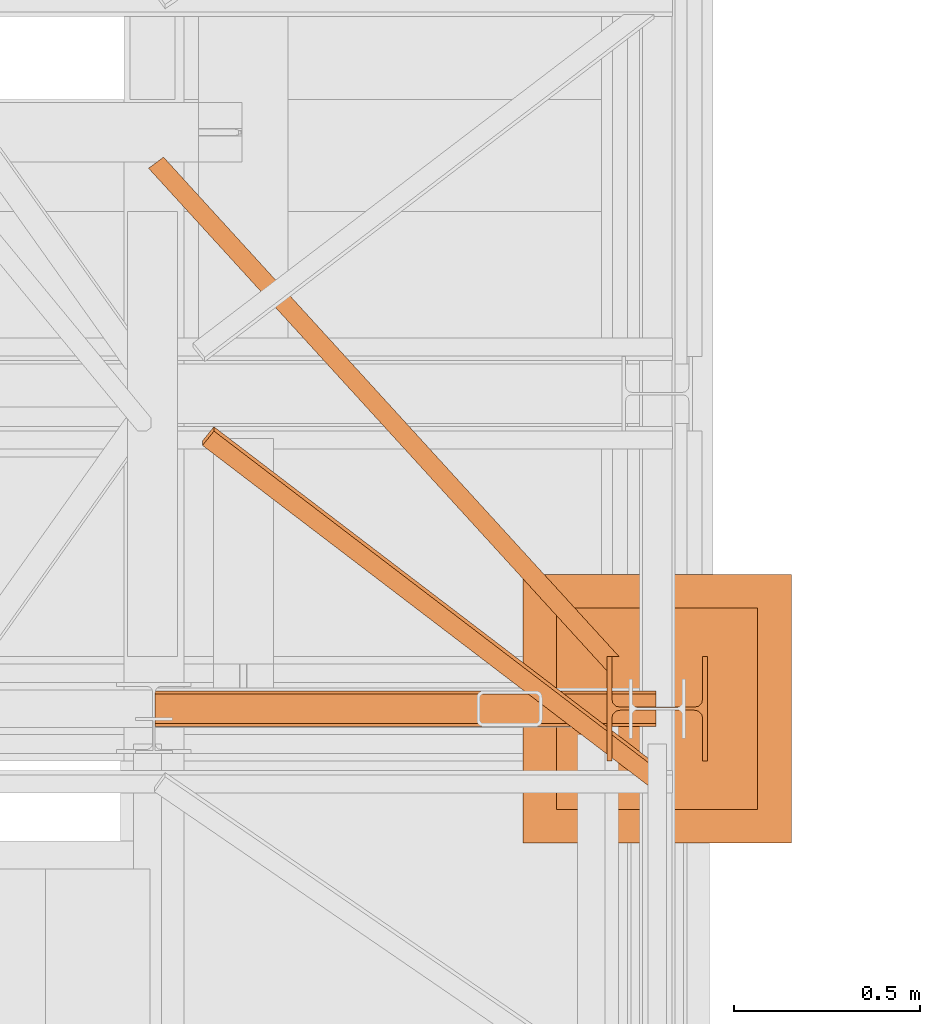
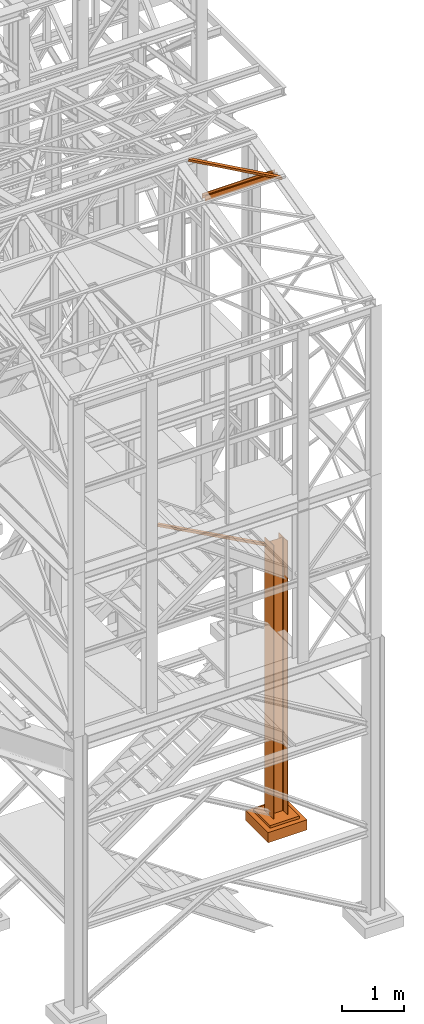
# One storey, part 60 of 208: 5 proxies.
"""IFC2X3 building model written with IfcOpenShell, lengths in millimetres."""

from ifc_helpers import new_model, entity, si_unit, converted_unit, frame, origin, origin_with_axes, place, context, subcontext, project, spatial, faceted_brep, element, save


model = new_model("IFC2X3")

# Units and contexts
model_context = context("Model", 3, precision=1e-05, world=origin())
plan_context = context("Plan", 3, precision=1e-05, world=origin())
body_context = subcontext(model_context, "Body", "Model", "MODEL_VIEW")
ifc_project = project(units=[si_unit("LENGTHUNIT", "METRE", prefix="MILLI"), converted_unit("PLANEANGLEUNIT", "DEGREE", entity("IfcPlaneAngleMeasure", 0.0174532925199433), si_unit("PLANEANGLEUNIT", "RADIAN"), dimensions=[0, 0, 0, 0, 0, 0, 0]), si_unit("AREAUNIT", "SQUARE_METRE"), si_unit("VOLUMEUNIT", "CUBIC_METRE")], contexts=[model_context, plan_context])

# Building, storey
building_placement = place(None, origin())
building = spatial("IfcBuilding", under=ifc_project, at=building_placement, CompositionType="COMPLEX")
storey_placement = place(building_placement, origin_with_axes())
storey = spatial("IfcBuildingStorey", under=building, at=storey_placement, Name="Geschoss", CompositionType="ELEMENT")

# Proxies
proxy_1_placement = place(storey_placement, frame((6563.25496316425, -22202.57439091393, -65.01000000000022), z_axis=(0.0, 0.0, 1.0), x_axis=(1.0, 0.0, 0.0)))
element("IfcBuildingElementProxy", 1, at=proxy_1_placement, inside=storey, context=body_context, shape_type="Brep", body=[
    faceted_brep([(0.009999999999308784, 0.00999999999839929, 5350.00999463558), (0.009999999999308784, 280.0100011920913, 5350.010005364416), (13.00999654292991, 280.0100011920913, 5350.010005364416), (13.00999654292991, 168.0100014603122, 5350.010005364416), (15.49606157302787, 155.588920617698, 5350.010005364416), (24.58892149686744, 146.49606488481, 5350.010005364416), (37.01000047683647, 144.0100007860347, 5350.010005364416), (233.0100102519973, 144.0100007860347, 5350.010005364416), (245.4310892319663, 146.49606488481, 5350.010005364416), (254.5239491558059, 155.588920617698, 5350.010005364416), (257.0100141859039, 168.0100014603122, 5350.010005364416), (257.0100141859039, 280.0100011920913, 5350.010005364416), (270.0100107288345, 280.0100011920913, 5350.010005364416), (270.0100107288345, 0.00999999999839929, 5350.00999463558), (257.0100141859039, 0.00999999999839929, 5350.00999463558), (257.0100141859039, 112.0099997317775, 5350.00999463558), (254.5239491558059, 124.4310805743917, 5350.00999463558), (245.4310892319663, 133.5239363072797, 5350.00999463558), (233.0100102519973, 136.010000406055, 5350.00999463558), (37.01000047683647, 136.010000406055, 5350.00999463558), (24.58892149686744, 133.5239363072797, 5350.00999463558), (15.49606157302787, 124.4310805743917, 5350.00999463558), (13.00999654292991, 112.0099997317775, 5350.00999463558), (13.00999654292991, 0.00999999999839929, 5350.00999463558), (0.009999999999308784, 280.0100011920913, 5350.010005364416), (0.009999999999308784, 0.00999999999839929, 5350.00999463558), (0.009999999999308784, 0.00999999999839929, 0.01000000000021828), (0.009999999999308784, 280.0100011920913, 0.01000000000021828), (0.009999999999308784, 280.0100011920913, 5350.010005364416), (0.009999999999308784, 280.0100011920913, 0.01000000000021828), (13.00999654292991, 280.0100011920913, 0.01000000000021828), (13.00999654292991, 280.0100011920913, 5350.010005364416), (13.00999654292991, 280.0100011920913, 5350.010005364416), (13.00999654292991, 280.0100011920913, 0.01000000000021828), (13.00999654292991, 168.0100014603122, 0.01000000000021828), (13.00999654292991, 168.0100014603122, 5350.010005364416), (13.00999654292991, 168.0100014603122, 5350.010005364416), (13.00999654292991, 168.0100014603122, 0.01000000000021828), (15.49606157302787, 155.588920617698, 0.01000000000021828), (15.49606157302787, 155.588920617698, 5350.010005364416), (15.49606157302787, 155.588920617698, 5350.010005364416), (15.49606157302787, 155.588920617698, 0.01000000000021828), (24.58892149686744, 146.49606488481, 0.01000000000021828), (24.58892149686744, 146.49606488481, 5350.010005364416), (24.58892149686744, 146.49606488481, 5350.010005364416), (24.58892149686744, 146.49606488481, 0.01000000000021828), (37.01000047683647, 144.0100007860347, 0.01000000000021828), (37.01000047683647, 144.0100007860347, 5350.010005364416), (37.01000047683647, 144.0100007860347, 5350.010005364416), (37.01000047683647, 144.0100007860347, 0.01000000000021828), (233.0100102519973, 144.0100007860347, 0.01000000000021828), (233.0100102519973, 144.0100007860347, 5350.010005364416), (233.0100102519973, 144.0100007860347, 5350.010005364416), (233.0100102519973, 144.0100007860347, 0.01000000000021828), (245.4310892319663, 146.49606488481, 0.01000000000021828), (245.4310892319663, 146.49606488481, 5350.010005364416), (245.4310892319663, 146.49606488481, 5350.010005364416), (245.4310892319663, 146.49606488481, 0.01000000000021828), (254.5239491558059, 155.588920617698, 0.01000000000021828), (254.5239491558059, 155.588920617698, 5350.010005364416), (254.5239491558059, 155.588920617698, 5350.010005364416), (254.5239491558059, 155.588920617698, 0.01000000000021828), (257.0100141859039, 168.0100014603122, 0.01000000000021828), (257.0100141859039, 168.0100014603122, 5350.010005364416), (257.0100141859039, 168.0100014603122, 5350.010005364416), (257.0100141859039, 168.0100014603122, 0.01000000000021828), (257.0100141859039, 280.0100011920913, 0.01000000000021828), (257.0100141859039, 280.0100011920913, 5350.010005364416), (257.0100141859039, 280.0100011920913, 5350.010005364416), (257.0100141859039, 280.0100011920913, 0.01000000000021828), (270.0100107288345, 280.0100011920913, 0.01000000000021828), (270.0100107288345, 280.0100011920913, 5350.010005364416), (270.0100107288345, 0.00999999999839929, 5350.00999463558), (270.0100107288345, 280.0100011920913, 5350.010005364416), (270.0100107288345, 280.0100011920913, 0.01000000000021828), (270.0100107288345, 0.00999999999839929, 0.01000000000021828), (257.0100141859039, 0.00999999999839929, 5350.00999463558), (270.0100107288345, 0.00999999999839929, 5350.00999463558), (270.0100107288345, 0.00999999999839929, 0.01000000000021828), (257.0100141859039, 0.00999999999839929, 0.01000000000021828), (257.0100141859039, 112.0099997317775, 5350.00999463558), (257.0100141859039, 0.00999999999839929, 5350.00999463558), (257.0100141859039, 0.00999999999839929, 0.01000000000021828), (257.0100141859039, 112.0099997317775, 0.01000000000021828), (254.5239491558059, 124.4310805743917, 5350.00999463558), (257.0100141859039, 112.0099997317775, 5350.00999463558), (257.0100141859039, 112.0099997317775, 0.01000000000021828), (254.5239491558059, 124.4310805743917, 0.01000000000021828), (245.4310892319663, 133.5239363072797, 5350.00999463558), (254.5239491558059, 124.4310805743917, 5350.00999463558), (254.5239491558059, 124.4310805743917, 0.01000000000021828), (245.4310892319663, 133.5239363072797, 0.01000000000021828), (233.0100102519973, 136.010000406055, 5350.00999463558), (245.4310892319663, 133.5239363072797, 5350.00999463558), (245.4310892319663, 133.5239363072797, 0.01000000000021828), (233.0100102519973, 136.010000406055, 0.01000000000021828), (37.01000047683647, 136.010000406055, 5350.00999463558), (233.0100102519973, 136.010000406055, 5350.00999463558), (233.0100102519973, 136.010000406055, 0.01000000000021828), (37.01000047683647, 136.010000406055, 0.01000000000021828), (24.58892149686744, 133.5239363072797, 5350.00999463558), (37.01000047683647, 136.010000406055, 5350.00999463558), (37.01000047683647, 136.010000406055, 0.01000000000021828), (24.58892149686744, 133.5239363072797, 0.01000000000021828), (15.49606157302787, 124.4310805743917, 5350.00999463558), (24.58892149686744, 133.5239363072797, 5350.00999463558), (24.58892149686744, 133.5239363072797, 0.01000000000021828), (15.49606157302787, 124.4310805743917, 0.01000000000021828), (13.00999654292991, 112.0099997317775, 5350.00999463558), (15.49606157302787, 124.4310805743917, 5350.00999463558), (15.49606157302787, 124.4310805743917, 0.01000000000021828), (13.00999654292991, 112.0099997317775, 0.01000000000021828), (13.00999654292991, 0.00999999999839929, 5350.00999463558), (13.00999654292991, 112.0099997317775, 5350.00999463558), (13.00999654292991, 112.0099997317775, 0.01000000000021828), (13.00999654292991, 0.00999999999839929, 0.01000000000021828), (0.009999999999308784, 0.00999999999839929, 5350.00999463558), (13.00999654292991, 0.00999999999839929, 5350.00999463558), (13.00999654292991, 0.00999999999839929, 0.01000000000021828), (0.009999999999308784, 0.00999999999839929, 0.01000000000021828), (0.009999999999308784, 0.00999999999839929, 0.01000000000021828), (13.00999654292991, 0.00999999999839929, 0.01000000000021828), (13.00999654292991, 112.0099997317775, 0.01000000000021828), (15.49606157302787, 124.4310805743917, 0.01000000000021828), (24.58892149686744, 133.5239363072797, 0.01000000000021828), (37.01000047683647, 136.010000406055, 0.01000000000021828), (233.0100102519973, 136.010000406055, 0.01000000000021828), (245.4310892319663, 133.5239363072797, 0.01000000000021828), (254.5239491558059, 124.4310805743917, 0.01000000000021828), (257.0100141859039, 112.0099997317775, 0.01000000000021828), (257.0100141859039, 0.00999999999839929, 0.01000000000021828), (270.0100107288345, 0.00999999999839929, 0.01000000000021828), (270.0100107288345, 280.0100011920913, 0.01000000000021828), (257.0100141859039, 280.0100011920913, 0.01000000000021828), (257.0100141859039, 168.0100014603122, 0.01000000000021828), (254.5239491558059, 155.588920617698, 0.01000000000021828), (245.4310892319663, 146.49606488481, 0.01000000000021828), (233.0100102519973, 144.0100007860347, 0.01000000000021828), (37.01000047683647, 144.0100007860347, 0.01000000000021828), (24.58892149686744, 146.49606488481, 0.01000000000021828), (15.49606157302787, 155.588920617698, 0.01000000000021828), (13.00999654292991, 168.0100014603122, 0.01000000000021828), (13.00999654292991, 280.0100011920913, 0.01000000000021828), (0.009999999999308784, 280.0100011920913, 0.01000000000021828)], [[[0, 1, 2, 3, 4, 5, 6, 7, 8, 9, 10, 11, 12, 13, 14, 15, 16, 17, 18, 19, 20, 21, 22, 23]], [[24, 25, 26, 27]], [[28, 29, 30, 31]], [[32, 33, 34, 35]], [[36, 37, 38, 39]], [[40, 41, 42, 43]], [[44, 45, 46, 47]], [[48, 49, 50, 51]], [[52, 53, 54, 55]], [[56, 57, 58, 59]], [[60, 61, 62, 63]], [[64, 65, 66, 67]], [[68, 69, 70, 71]], [[72, 73, 74, 75]], [[76, 77, 78, 79]], [[80, 81, 82, 83]], [[84, 85, 86, 87]], [[88, 89, 90, 91]], [[92, 93, 94, 95]], [[96, 97, 98, 99]], [[100, 101, 102, 103]], [[104, 105, 106, 107]], [[108, 109, 110, 111]], [[112, 113, 114, 115]], [[116, 117, 118, 119]], [[120, 121, 122, 123, 124, 125, 126, 127, 128, 129, 130, 131, 132, 133, 134, 135, 136, 137, 138, 139, 140, 141, 142, 143]]], orient=[[False], [False], [False], [False], [False], [False], [False], [False], [False], [False], [False], [False], [False], [False], [False], [False], [False], [False], [False], [False], [False], [False], [False], [False], [False], [False]]),
])
proxy_2_placement = place(storey_placement, frame((6337.754970998533, -22422.57439031789, -315.01), z_axis=(0.0, 0.0, 1.0), x_axis=(1.0, 0.0, 0.0)))
element("IfcBuildingElementProxy", 2, at=proxy_2_placement, inside=storey, context=body_context, shape_type="Brep", body=[
    faceted_brep([(630.0100000000002, 630.0099999999984, 250.01), (630.0100000000002, 90.0099999999984, 250.01), (90.01000000000022, 90.0099999999984, 250.01), (90.01000000000022, 630.0099999999984, 250.01), (630.0100000000002, 630.0099999999984, 200.01), (630.0100000000002, 90.0099999999984, 200.01), (630.0100000000002, 90.0099999999984, 250.01), (630.0100000000002, 630.0099999999984, 250.01), (90.01000000000022, 630.0099999999984, 200.01), (630.0100000000002, 630.0099999999984, 200.01), (630.0100000000002, 630.0099999999984, 250.01), (90.01000000000022, 630.0099999999984, 250.01), (90.01000000000022, 90.0099999999984, 200.01), (90.01000000000022, 630.0099999999984, 200.01), (90.01000000000022, 630.0099999999984, 250.01), (90.01000000000022, 90.0099999999984, 250.01), (630.0100000000002, 90.0099999999984, 200.01), (90.01000000000022, 90.0099999999984, 200.01), (90.01000000000022, 90.0099999999984, 250.01), (630.0100000000002, 90.0099999999984, 250.01), (720.0100000000002, 0.00999999999839929, 0.009999999999990905), (720.0100000000002, 720.0099999999984, 0.009999999999990905), (0.01000000000021828, 720.0099999999984, 0.009999999999990905), (0.01000000000021828, 0.00999999999839929, 0.009999999999990905), (720.0100000000002, 720.0099999999984, 200.01), (720.0100000000002, 0.00999999999839929, 200.01), (0.01000000000021828, 0.00999999999839929, 200.01), (0.01000000000021828, 720.0099999999984, 200.01), (90.01000000000022, 90.0099999999984, 200.01), (630.0100000000002, 90.0099999999984, 200.01), (630.0100000000002, 630.0099999999984, 200.01), (90.01000000000022, 630.0099999999984, 200.01), (720.0100000000002, 720.0099999999984, 0.009999999999990905), (720.0100000000002, 0.00999999999839929, 0.009999999999990905), (720.0100000000002, 0.00999999999839929, 200.01), (720.0100000000002, 720.0099999999984, 200.01), (0.01000000000021828, 720.0099999999984, 0.009999999999990905), (720.0100000000002, 720.0099999999984, 0.009999999999990905), (720.0100000000002, 720.0099999999984, 200.01), (0.01000000000021828, 720.0099999999984, 200.01), (0.01000000000021828, 0.00999999999839929, 0.009999999999990905), (0.01000000000021828, 720.0099999999984, 0.009999999999990905), (0.01000000000021828, 720.0099999999984, 200.01), (0.01000000000021828, 0.00999999999839929, 200.01), (720.0100000000002, 0.00999999999839929, 0.009999999999990905), (0.01000000000021828, 0.00999999999839929, 0.009999999999990905), (0.01000000000021828, 0.00999999999839929, 200.01), (720.0100000000002, 0.00999999999839929, 200.01)], [[[0, 1, 2, 3]], [[4, 5, 6, 7]], [[8, 9, 10, 11]], [[12, 13, 14, 15]], [[16, 17, 18, 19]], [[20, 21, 22, 23]], [[24, 25, 26, 27], [28, 29, 30, 31]], [[32, 33, 34, 35]], [[36, 37, 38, 39]], [[40, 41, 42, 43]], [[44, 45, 46, 47]]], orient=[[False], [False], [False], [False], [False], [False], [False, False], [False], [False], [False], [False]]),
])
proxy_3_placement = place(storey_placement, frame((5333.759663873269, -21961.05414175754, 5124.989999999998), z_axis=(0.0, 0.0, 1.0), x_axis=(1.0, 0.0, 0.0)))
element("IfcBuildingElementProxy", 3, at=proxy_3_placement, inside=storey, context=body_context, shape_type="Brep", body=[
    faceted_brep([(40.1206636007646, 1377.774890675592, 50.01000000000022), (40.1206636007646, 1377.774890675592, 0.01000000000021828), (1261.7460710356, 38.48975203570444, 0.01000000000021828), (1261.746071035599, 38.48975203570444, 50.01000000000022), (40.1206636007646, 1377.774890675592, 0.01000000000021828), (0.01000000000021828, 1347.923011915511, 0.01000000000021828), (1229.50529929098, 0.00999999999839929, 0.01000000000021828), (1229.50529929098, 38.48975203570444, 0.01000000000021828), (1261.7460710356, 38.48975203570444, 0.01000000000021828), (0.01000000000021828, 1347.923011915511, 0.01000000000021828), (0.01000000000021828, 1347.923011915511, 50.01000000000022), (1229.505299290981, 0.00999999999839929, 50.01000000000022), (1229.50529929098, 0.00999999999839929, 0.01000000000021828), (0.01000000000021828, 1347.923011915511, 50.01000000000022), (40.1206636007646, 1377.774890675592, 50.01000000000022), (1261.746071035599, 38.48975203570444, 50.01000000000022), (1229.50529929098, 38.48975203570444, 50.01000000000022), (1229.505299290981, 0.00999999999839929, 50.01000000000022), (40.1206636007646, 1377.774890675592, 50.01000000000022), (0.01000000000021828, 1347.923011915511, 50.01000000000022), (0.01000000000021828, 1347.923011915511, 0.01000000000021828), (40.1206636007646, 1377.774890675592, 0.01000000000021828), (36.9118105127036, 1375.386740374783, 4.010000000000218), (3.218853088061223, 1350.31116221632, 4.010000000000218), (3.218853088061223, 1350.31116221632, 46.01000000000022), (36.9118105127036, 1375.386740374783, 46.01000000000022), (36.9118105127036, 1375.386740374783, 46.01000000000022), (1256.358872948355, 38.48975203570444, 46.01000000000022), (1256.358872948355, 38.48975203570444, 4.010000000000218), (36.9118105127036, 1375.386740374783, 4.010000000000218), (36.9118105127036, 1375.386740374783, 4.010000000000218), (1256.358872948355, 38.48975203570444, 4.010000000000218), (1229.50529929098, 38.48975203570444, 4.010000000000218), (1229.50529929098, 5.916061132360483, 4.010000000000218), (3.218853088061223, 1350.31116221632, 4.010000000000218), (3.218853088061223, 1350.31116221632, 4.010000000000218), (1229.50529929098, 5.916061132360483, 4.010000000000218), (1229.50529929098, 5.916061132360483, 46.01000000000022), (3.218853088061223, 1350.31116221632, 46.01000000000022), (3.218853088061223, 1350.31116221632, 46.01000000000022), (1229.50529929098, 5.916061132360483, 46.01000000000022), (1229.50529929098, 38.48975203570444, 46.01000000000022), (1256.358872948355, 38.48975203570444, 46.01000000000022), (36.9118105127036, 1375.386740374783, 46.01000000000022), (1229.50529929098, 38.48975203570444, 50.01000000000022), (1261.746071035599, 38.48975203570444, 50.01000000000022), (1261.7460710356, 38.48975203570444, 0.01000000000021828), (1229.50529929098, 38.48975203570444, 0.01000000000021828), (1229.50529929098, 38.48975203570444, 4.010000000000218), (1256.358872948355, 38.48975203570444, 4.010000000000218), (1256.358872948355, 38.48975203570444, 46.01000000000022), (1229.50529929098, 38.48975203570444, 46.01000000000022), (1229.50529929098, 38.48975203570444, 0.01000000000021828), (1229.50529929098, 0.00999999999839929, 0.01000000000021828), (1229.505299290981, 0.00999999999839929, 50.01000000000022), (1229.50529929098, 38.48975203570444, 50.01000000000022), (1229.50529929098, 38.48975203570444, 46.01000000000022), (1229.50529929098, 5.916061132360483, 46.01000000000022), (1229.50529929098, 5.916061132360483, 4.010000000000218), (1229.50529929098, 38.48975203570444, 4.010000000000218)], [[[0, 1, 2, 3]], [[4, 5, 6, 7, 8]], [[9, 10, 11, 12]], [[13, 14, 15, 16, 17]], [[18, 19, 20, 21], [22, 23, 24, 25]], [[26, 27, 28, 29]], [[30, 31, 32, 33, 34]], [[35, 36, 37, 38]], [[39, 40, 41, 42, 43]], [[44, 45, 46, 47, 48, 49, 50, 51]], [[52, 53, 54, 55, 56, 57, 58, 59]]], orient=[[False], [False], [False], [False], [False, False], [False], [False], [False], [False], [False], [False]]),
])
proxy_4_placement = place(storey_placement, frame((5351.254972280036, -22111.04177386488, 12392.75857612322), z_axis=(0.0, 0.0, 1.0), x_axis=(1.0, 0.0, 0.0)))
element("IfcBuildingElementProxy", 4, at=proxy_4_placement, inside=storey, context=body_context, shape_type="Brep", body=[
    faceted_brep([(1344.009999947846, 8.010000000002037, 0.01000000000021828), (1344.009999947846, 0.01000000000203727, 0.01000000000021828), (1344.009999947846, 0.01000000000203727, 100.0100000000002), (1344.009999947846, 8.010000000002037, 100.0100000000002), (1344.009999947846, 8.010000000002037, 52.51000000000022), (1344.009999947846, 88.01000000000204, 52.51000000000022), (1344.009999947846, 88.01000000000204, 100.0100000000002), (1344.009999947846, 96.01000000000204, 100.0100000000002), (1344.009999947846, 96.01000000000204, 0.01000000000021828), (1344.009999947846, 88.01000000000204, 0.01000000000021828), (1344.009999947846, 88.01000000000204, 47.51000000000022), (1344.009999947846, 8.010000000002037, 47.51000000000022), (1344.009999947846, 0.01000000000203727, 0.01000000000021828), (1344.009999947846, 8.010000000002037, 0.01000000000021828), (0.01000000000021828, 8.010000000005675, 0.01000000000021828), (0.01000000000021828, 0.01000000000567525, 0.01000000000021828), (1344.009999947846, 0.01000000000203727, 100.0100000000002), (1344.009999947846, 0.01000000000203727, 0.01000000000021828), (0.01000000000021828, 0.01000000000567525, 0.01000000000021828), (0.01000000000021828, 0.01000000000567525, 100.0100000000002), (1344.009999947846, 8.010000000002037, 100.0100000000002), (1344.009999947846, 0.01000000000203727, 100.0100000000002), (0.01000000000021828, 0.01000000000567525, 100.0100000000002), (0.01000000000021828, 8.010000000005675, 100.0100000000002), (1344.009999947846, 8.010000000002037, 52.51000000000022), (1344.009999947846, 8.010000000002037, 100.0100000000002), (0.01000000000021828, 8.010000000005675, 100.0100000000002), (0.01000000000021828, 8.010000000005675, 52.51000000000022), (1344.009999947846, 88.01000000000204, 52.51000000000022), (1344.009999947846, 8.010000000002037, 52.51000000000022), (0.01000000000021828, 8.010000000005675, 52.51000000000022), (0.01000000000021828, 88.01000000000568, 52.51000000000022), (1344.009999947846, 88.01000000000204, 100.0100000000002), (1344.009999947846, 88.01000000000204, 52.51000000000022), (0.01000000000021828, 88.01000000000568, 52.51000000000022), (0.01000000000021828, 88.01000000000568, 100.0100000000002), (1344.009999947846, 96.01000000000204, 100.0100000000002), (1344.009999947846, 88.01000000000204, 100.0100000000002), (0.01000000000021828, 88.01000000000568, 100.0100000000002), (0.01000000000021828, 96.01000000000568, 100.0100000000002), (1344.009999947846, 96.01000000000204, 0.01000000000021828), (1344.009999947846, 96.01000000000204, 100.0100000000002), (0.01000000000021828, 96.01000000000568, 100.0100000000002), (0.01000000000021828, 96.01000000000568, 0.01000000000021828), (1344.009999947846, 88.01000000000204, 0.01000000000021828), (1344.009999947846, 96.01000000000204, 0.01000000000021828), (0.01000000000021828, 96.01000000000568, 0.01000000000021828), (0.01000000000021828, 88.01000000000568, 0.01000000000021828), (1344.009999947846, 88.01000000000204, 47.51000000000022), (1344.009999947846, 88.01000000000204, 0.01000000000021828), (0.01000000000021828, 88.01000000000568, 0.01000000000021828), (0.01000000000021828, 88.01000000000568, 47.51000000000022), (1344.009999947846, 8.010000000002037, 47.51000000000022), (1344.009999947846, 88.01000000000204, 47.51000000000022), (0.01000000000021828, 88.01000000000568, 47.51000000000022), (0.01000000000021828, 8.010000000005675, 47.51000000000022), (1344.009999947846, 8.010000000002037, 0.01000000000021828), (1344.009999947846, 8.010000000002037, 47.51000000000022), (0.01000000000021828, 8.010000000005675, 47.51000000000022), (0.01000000000021828, 8.010000000005675, 0.01000000000021828), (0.01000000000021828, 8.010000000005675, 0.01000000000021828), (0.01000000000021828, 8.010000000005675, 47.51000000000022), (0.01000000000021828, 88.01000000000568, 47.51000000000022), (0.01000000000021828, 88.01000000000568, 0.01000000000021828), (0.01000000000021828, 96.01000000000568, 0.01000000000021828), (0.01000000000021828, 96.01000000000568, 100.0100000000002), (0.01000000000021828, 88.01000000000568, 100.0100000000002), (0.01000000000021828, 88.01000000000568, 52.51000000000022), (0.01000000000021828, 8.010000000005675, 52.51000000000022), (0.01000000000021828, 8.010000000005675, 100.0100000000002), (0.01000000000021828, 0.01000000000567525, 100.0100000000002), (0.01000000000021828, 0.01000000000567525, 0.01000000000021828)], [[[0, 1, 2, 3, 4, 5, 6, 7, 8, 9, 10, 11]], [[12, 13, 14, 15]], [[16, 17, 18, 19]], [[20, 21, 22, 23]], [[24, 25, 26, 27]], [[28, 29, 30, 31]], [[32, 33, 34, 35]], [[36, 37, 38, 39]], [[40, 41, 42, 43]], [[44, 45, 46, 47]], [[48, 49, 50, 51]], [[52, 53, 54, 55]], [[56, 57, 58, 59]], [[60, 61, 62, 63, 64, 65, 66, 67, 68, 69, 70, 71]]], orient=[[False], [False], [False], [False], [False], [False], [False], [False], [False], [False], [False], [False], [False], [False]]),
])
proxy_5_placement = place(storey_placement, frame((5478.19557862512, -22278.63157839609, 12438.25044331833), z_axis=(0.0, 0.0, 1.0), x_axis=(1.0, 0.0, 0.0)))
element("IfcBuildingElementProxy", 5, at=proxy_5_placement, inside=storey, context=body_context, shape_type="Brep", body=[
    faceted_brep([(30.90667059062071, 972.1023318377374, 236.0484991148824), (31.154023856604, 960.4557553133018, 284.6725268339269), (0.2573532659826014, 922.1902820077885, 275.6642362569128), (0.01000000000021828, 933.8368585322241, 227.0402085378719), (1211.503616119682, 71.07412996872154, 14.22569010463667), (1211.750969385666, 59.42755344428952, 62.8497178236812), (31.154023856604, 960.4557553133018, 284.6725268339269), (30.90667059062071, 972.1023318377374, 236.0484991148824), (1208.32203940917, 11.6565765244377, 0.00999999999839929), (1211.503616119682, 71.07412996872154, 14.22569010463667), (30.90667059062071, 972.1023318377374, 236.0484991148824), (0.01000000000021828, 933.8368585322241, 227.0402085378719), (1208.569392675153, 0.00999999999839929, 48.6340277190393), (1208.32203940917, 11.6565765244377, 0.00999999999839929), (0.01000000000021828, 933.8368585322241, 227.0402085378719), (0.2573532659826014, 922.1902820077885, 275.6642362569128), (1211.750969385666, 59.42755344428952, 62.8497178236812), (1208.569392675153, 0.00999999999839929, 48.6340277190393), (0.2573532659826014, 922.1902820077885, 275.6642362569128), (31.154023856604, 960.4557553133018, 284.6725268339269), (1211.503616119682, 71.07412996872154, 14.22569010463667), (1208.32203940917, 11.6565765244377, 0.00999999999839929), (1208.569392675153, 0.00999999999839929, 48.6340277190393), (1211.750969385666, 59.42755344428952, 62.8497178236812)], [[[0, 1, 2, 3]], [[4, 5, 6, 7]], [[8, 9, 10, 11]], [[12, 13, 14, 15]], [[16, 17, 18, 19]], [[20, 21, 22, 23]]], orient=[[False], [False], [False], [False], [False], [False]]),
])

save(model, "model.ifc")
